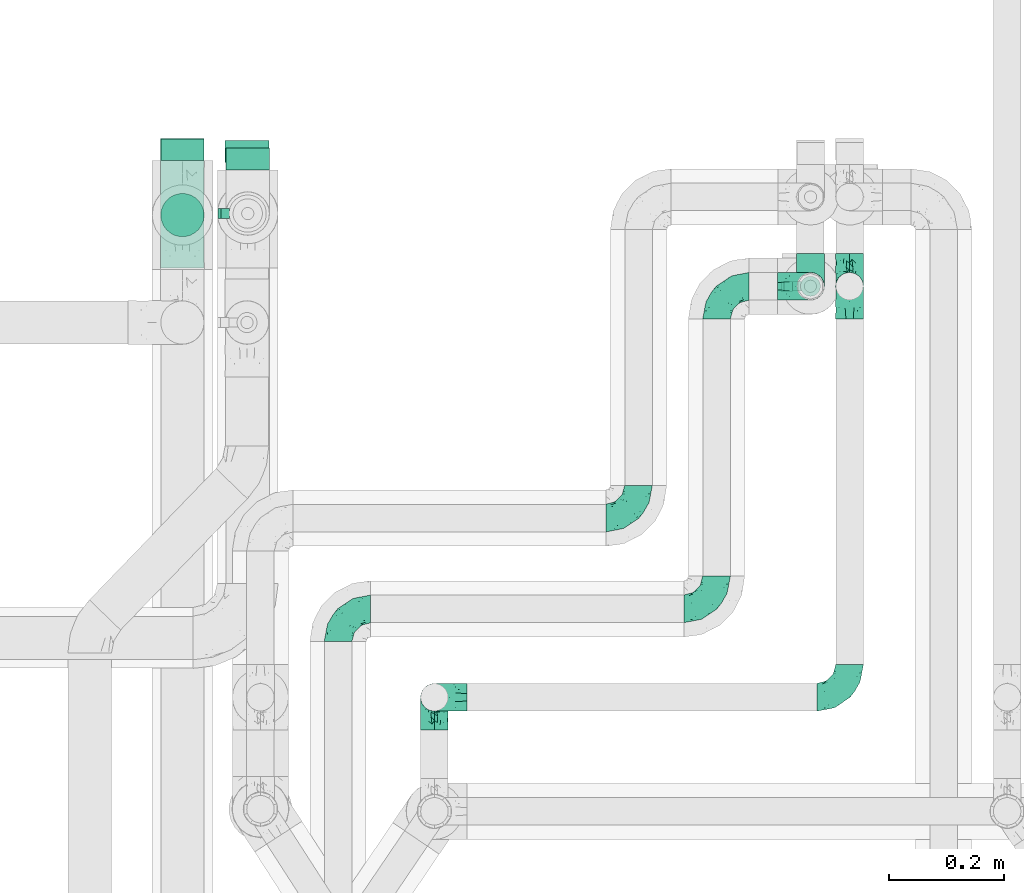
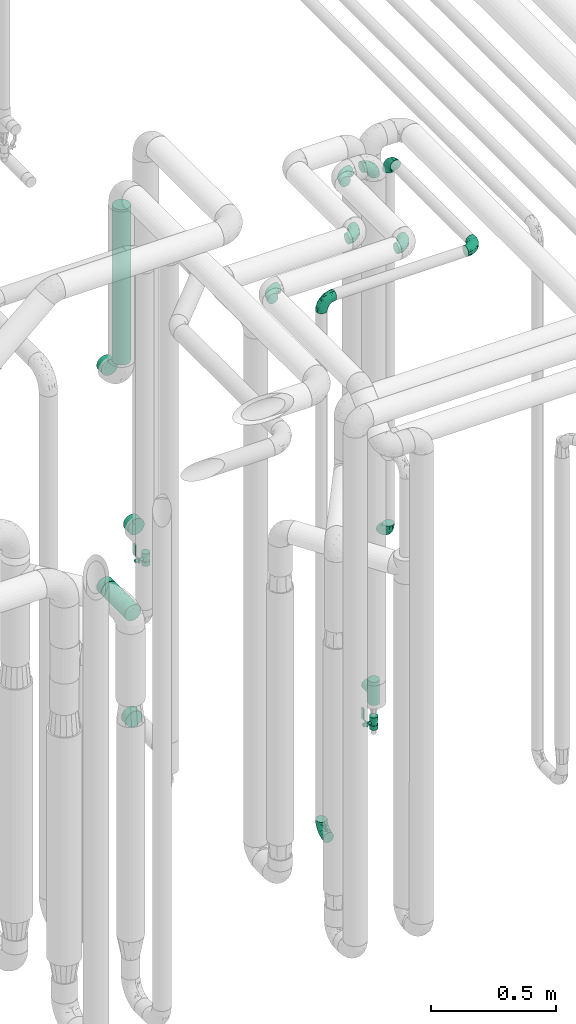
# One storey, part 672 of 824: 15 flow fittings, 2 flow controllers, 2 flow segments.
"""IFC2X3 building model written with IfcOpenShell, lengths in millimetres."""

from ifc_helpers import new_model, entity, si_unit, converted_unit, derived_unit, direction, frame, origin, origin_2d_with_axis, place, context, subcontext, project, spatial, polyline, circle, outline, extrude, faceted_brep, source, transform, mapped, material, material_list, type_object, type_shapes, element, save


model = new_model("IFC2X3")

# Units and contexts
model_context = context("Model", 3, precision=0.01, world=origin(), true_north=direction((6.12303176911189e-17, 1.0)))
body_context = subcontext(model_context, "Body", "Model", "MODEL_VIEW")
ifc_project = project(units=[si_unit("LENGTHUNIT", "METRE", prefix="MILLI"), si_unit("AREAUNIT", "SQUARE_METRE"), si_unit("VOLUMEUNIT", "CUBIC_METRE"), converted_unit("PLANEANGLEUNIT", "DEGREE", entity("IfcRatioMeasure", 0.0174532925199433), si_unit("PLANEANGLEUNIT", "RADIAN"), dimensions=[0, 0, 0, 0, 0, 0, 0]), si_unit("MASSUNIT", "GRAM", prefix="KILO"), derived_unit("MASSDENSITYUNIT", [(si_unit("MASSUNIT", "GRAM", prefix="KILO"), 1), (si_unit("LENGTHUNIT", "METRE"), -3)]), derived_unit("MOMENTOFINERTIAUNIT", [(si_unit("LENGTHUNIT", "METRE"), 4)]), si_unit("TIMEUNIT", "SECOND"), si_unit("FREQUENCYUNIT", "HERTZ"), si_unit("THERMODYNAMICTEMPERATUREUNIT", "DEGREE_CELSIUS"), derived_unit("THERMALTRANSMITTANCEUNIT", [(si_unit("MASSUNIT", "GRAM", prefix="KILO"), 1), (si_unit("THERMODYNAMICTEMPERATUREUNIT", "KELVIN"), -1), (si_unit("TIMEUNIT", "SECOND"), -3)]), derived_unit("VOLUMETRICFLOWRATEUNIT", [(si_unit("LENGTHUNIT", "METRE"), 3), (si_unit("TIMEUNIT", "SECOND"), -1)]), derived_unit("MASSFLOWRATEUNIT", [(si_unit("MASSUNIT", "GRAM", prefix="KILO"), 1), (si_unit("TIMEUNIT", "SECOND"), -1)]), derived_unit("ROTATIONALFREQUENCYUNIT", [(si_unit("TIMEUNIT", "SECOND"), -1)]), si_unit("ELECTRICCURRENTUNIT", "AMPERE"), si_unit("ELECTRICVOLTAGEUNIT", "VOLT"), si_unit("POWERUNIT", "WATT"), si_unit("FORCEUNIT", "NEWTON", prefix="KILO"), si_unit("ILLUMINANCEUNIT", "LUX"), si_unit("LUMINOUSFLUXUNIT", "LUMEN"), si_unit("LUMINOUSINTENSITYUNIT", "CANDELA"), derived_unit("USERDEFINED", [(si_unit("MASSUNIT", "GRAM", prefix="KILO"), -1), (si_unit("LENGTHUNIT", "METRE"), -2), (si_unit("TIMEUNIT", "SECOND"), 3), (si_unit("LUMINOUSFLUXUNIT", "LUMEN"), 1)]), derived_unit("LINEARVELOCITYUNIT", [(si_unit("LENGTHUNIT", "METRE"), 1), (si_unit("TIMEUNIT", "SECOND"), -1)]), si_unit("PRESSUREUNIT", "PASCAL"), derived_unit("USERDEFINED", [(si_unit("LENGTHUNIT", "METRE"), -2), (si_unit("MASSUNIT", "GRAM", prefix="KILO"), 1), (si_unit("TIMEUNIT", "SECOND"), -2)]), derived_unit("LINEARFORCEUNIT", [(si_unit("MASSUNIT", "GRAM", prefix="KILO"), 1), (si_unit("LENGTHUNIT", "METRE"), 1), (si_unit("TIMEUNIT", "SECOND"), -2), (si_unit("LENGTHUNIT", "METRE"), -1)]), derived_unit("PLANARFORCEUNIT", [(si_unit("MASSUNIT", "GRAM", prefix="KILO"), 1), (si_unit("LENGTHUNIT", "METRE"), 1), (si_unit("TIMEUNIT", "SECOND"), -2), (si_unit("LENGTHUNIT", "METRE"), -2)])], contexts=[model_context])

# Site, building, storey
site_placement = place(None, origin())
site = spatial("IfcSite", under=ifc_project, at=site_placement, CompositionType="ELEMENT")
building_placement = place(site_placement, origin())
building = spatial("IfcBuilding", under=site, at=building_placement, CompositionType="ELEMENT")
storey_placement = place(building_placement, frame((0.0, 0.0, 28200.0)))
storey = spatial("IfcBuildingStorey", under=building, at=storey_placement, CompositionType="ELEMENT", Elevation=28200.0)

# Flow segments
pipe_segment_type = type_object("IfcPipeSegmentType", PredefinedType="NOTDEFINED")
flow_segment_1_placement = place(storey_placement, frame((46517.3, 15183.04, 1125.65)))
element("IfcFlowSegment", 1, at=flow_segment_1_placement, inside=storey, type_object=pipe_segment_type, context=body_context, shape_type="SweptSolid", body=[
    extrude(circle(Radius=37.75, at=origin_2d_with_axis()), frame((39.35, 0.0, 39.35), z_axis=(0.0, 1.0, 0.0), x_axis=(1.0, 0.0, 0.0)), (0.0, 0.0, 1.0), 188.200000000003),
])
flow_segment_2_placement = place(storey_placement, frame((46517.43, 15236.02, 2345.05)))
element("IfcFlowSegment", 2, at=flow_segment_2_placement, inside=storey, type_object=pipe_segment_type, context=body_context, shape_type="SweptSolid", body=[
    extrude(circle(Radius=37.75, at=origin_2d_with_axis()), frame((39.35, 39.35, 0.0)), (0.0, 0.0, 1.0), 760.000000000018),
])

# Flow controllers
ifc_material = material()
ifc_material_list = material_list([ifc_material, ifc_material, ifc_material, ifc_material, ifc_material])
valve_type = type_object("IfcValveType", PredefinedType="NOTDEFINED", material=ifc_material_list)
shared_shape_1 = source(origin(), body_context, "Body", "SweptSolid", [
    extrude(circle(Radius=17.5, at=origin_2d_with_axis()), frame((-30.5, 0.0, 0.0), z_axis=(1.0, 0.0, 0.0), x_axis=(0.0, 1.0, 0.0)), (0.0, 0.0, 1.0), 20.3333333333333),
    extrude(circle(Radius=16.0, at=origin_2d_with_axis()), frame((-10.17, 0.0, 0.0), z_axis=(1.0, 0.0, 0.0), x_axis=(0.0, 1.0, 0.0)), (0.0, 0.0, 1.0), 20.3333333333333),
    extrude(circle(Radius=17.5, at=origin_2d_with_axis()), frame((10.17, 0.0, 0.0), z_axis=(1.0, 0.0, 0.0), x_axis=(0.0, 1.0, 0.0)), (0.0, 0.0, 1.0), 20.3333333333333),
    extrude(outline(polyline([(-38.75, -5.0), (-38.75, -10.0), (-17.92, -10.0), (2.08, 5.0), (56.25, 5.0), (56.25, 10.0), (0.42, 10.0), (-19.58, -5.0), (-38.75, -5.0)])), frame((28.75, -8.75, 41.5), z_axis=(0.0, -1.0, 0.0), x_axis=(1.0, 0.0, 0.0)), (0.0, 0.0, -1.0), 17.5),
    extrude(circle(Radius=8.0, at=origin_2d_with_axis()), origin(), (0.0, 0.0, 1.0), 49.0),
])
type_shapes(valve_type, [shared_shape_1])
for number, where, z_axis, x_axis in (
    (3, (47651.75, 15151.24, 267.75), (-1.0, 0.0, 0.0), (0.0, 0.0, 1.0)),
    (4, (46670.56, 15278.08, 1335.75), (-1.0, 0.0, 0.0), (0.0, 0.0, 1.0)),
):
    element("IfcFlowController", number, at=place(storey_placement, frame(where, z_axis=z_axis, x_axis=x_axis)), inside=storey, type_object=valve_type, material=ifc_material, context=body_context, shape_type="MappedRepresentation", body=[
        mapped(shared_shape_1, transform((0.0, 0.0, 0.0), scale=1.0)),
    ])

# Flow fittings
pipe_fitting_type_1 = type_object("IfcPipeFittingType", PredefinedType="NOTDEFINED", material=ifc_material)
shared_shape_2 = source(origin(), body_context, "Body", "SweptSolid", [
    extrude(circle(Radius=38.05, at=origin_2d_with_axis()), frame((0.0, 0.0, 0.0), z_axis=(1.0, 0.0, 0.0), x_axis=(0.0, 1.0, 0.0)), (0.0, 0.0, 1.0), 38.0000000000003),
])
type_shapes(pipe_fitting_type_1, [shared_shape_2])
for number, where, z_axis, x_axis in (
    (5, (46556.77, 15370.36, 2250.05), (1.0, 0.0, 0.0), (0.0, 1.0, 0.0)),
    (6, (46670.56, 15354.08, 1442.25), (-1.0, 0.0, 0.0), (0.0, 1.0, 0.0)),
    (7, (46556.64, 15371.24, 1165.0), (0.0, 0.0, 1.0), (0.0, 1.0, 0.0)),
    (8, (46669.38, 15367.24, 494.0), (0.0, 0.0, 1.0), (0.0, 1.0, 0.0)),
):
    element("IfcFlowFitting", number, at=place(storey_placement, frame(where, z_axis=z_axis, x_axis=x_axis)), inside=storey, type_object=pipe_fitting_type_1, material=ifc_material, context=body_context, shape_type="MappedRepresentation", body=[
        mapped(shared_shape_2, transform((0.0, 0.0, 0.0), scale=1.0)),
    ])
pipe_fitting_type_2 = type_object("IfcPipeFittingType", PredefinedType="NOTDEFINED", material=ifc_material)
shared_shape_3 = source(origin(), body_context, "Body", "Brep", [
    faceted_brep([(-57.0, 12.07, -20.91), (-57.0, 6.25, -23.33), (-57.0, 0.0, -24.15), (-57.0, -6.25, -23.33), (-57.0, -12.08, -20.91), (-57.0, -17.08, -17.08), (-57.0, -20.91, -12.08), (-57.0, -23.33, -6.25), (-57.0, -24.15, 0.0), (-57.0, -23.33, 6.25), (-57.0, -20.91, 12.07), (-57.0, -17.08, 17.08), (-57.0, -12.08, 20.91), (-57.0, -6.25, 23.33), (-57.0, 0.0, 24.15), (-57.0, 6.25, 23.33), (-57.0, 12.07, 20.91), (-57.0, 17.08, 17.08), (-57.0, 20.91, 12.07), (-57.0, 23.33, 6.25), (-57.0, 24.15, 0.0), (-57.0, 23.33, -6.25), (-57.0, 20.91, -12.08), (-57.0, 17.08, -17.08), (0.0, 57.0, -24.15), (-6.25, 57.0, -23.33), (-12.07, 57.0, -20.91), (-17.08, 57.0, -17.08), (-20.91, 57.0, -12.08), (-23.33, 57.0, -6.25), (-24.15, 57.0, 0.0), (-23.33, 57.0, 6.25), (-20.91, 57.0, 12.07), (-17.08, 57.0, 17.08), (-12.07, 57.0, 20.91), (-6.25, 57.0, 23.33), (0.0, 57.0, 24.15), (6.25, 57.0, 23.33), (12.08, 57.0, 20.91), (17.08, 57.0, 17.08), (20.91, 57.0, 12.07), (23.33, 57.0, 6.25), (24.15, 57.0, 0.0), (23.33, 57.0, -6.25), (20.91, 57.0, -12.08), (17.08, 57.0, -17.08), (12.08, 57.0, -20.91), (6.25, 57.0, -23.33), (14.9, 21.14, 6.17), (13.61, 24.64, 12.48), (6.23, 8.95, 8.98), (-41.47, -21.06, 0.0), (-41.92, -18.38, 13.72), (-24.64, -13.61, 12.48), (-37.37, -13.24, 18.15), (-6.8, -4.93, 8.18), (-21.76, -15.19, 6.22), (-12.78, -9.18, 0.0), (-37.73, -20.51, 7.75), (-7.38, 7.38, 20.24), (-23.37, -4.26, 20.42), (-11.9, -3.19, 15.86), (-42.14, -8.7, 21.82), (13.24, 37.37, 18.15), (9.33, 23.53, 16.85), (4.26, 23.37, 20.42), (2.77, 10.92, 15.55), (-29.46, 0.91, 23.52), (-44.13, 20.56, 15.69), (-39.25, 26.33, 10.88), (-49.02, 22.92, 9.96), (-34.58, 23.87, 17.15), (-15.8, 6.8, 22.81), (-8.67, 20.47, 23.88), (-18.12, 12.9, 24.08), (-48.29, 14.92, 19.65), (-44.06, -2.85, 23.78), (-9.23, 48.95, 22.58), (-3.78, 42.74, 24.07), (-40.34, 4.26, 24.09), (-44.02, 26.14, 5.46), (-44.04, 9.88, 22.74), (-4.95, 16.87, 22.52), (-2.75, 1.43, 12.5), (-25.48, 40.98, 10.71), (20.51, 37.73, 7.75), (18.38, 41.92, 13.72), (8.7, 42.14, 21.82), (-25.95, -17.97, 0.0), (2.85, 44.06, 23.78), (21.06, 41.47, 0.0), (17.97, 25.95, 0.0), (-24.04, -9.27, 17.13), (-33.26, 33.26, 5.86), (-28.55, 40.57, 0.0), (-40.57, 28.55, 0.0), (-25.29, 47.19, 4.06), (-27.01, 31.1, 16.77), (-15.7, 43.95, 19.9), (-20.27, 45.22, 15.61), (-30.53, 31.98, 12.64), (-11.28, 38.33, 22.92), (-9.97, 27.88, 24.09), (-20.15, 30.26, 21.25), (-31.25, 11.75, 23.64), (-28.75, 7.23, 24.15), (-29.53, 18.06, 22.27), (-28.44, 24.21, 20.02), (-37.55, 17.7, 20.26), (-15.88, 29.25, 22.99), (-20.82, 20.82, 23.44), (-0.91, 29.46, 23.52), (-13.5, -7.67, 12.04), (1.49, 1.56, 5.16), (8.86, 10.35, 4.59), (0.38, -0.38, 0.0), (9.18, 12.78, 0.0), (-37.37, -13.24, -18.15), (8.86, 10.35, -4.59), (-45.22, 20.27, -15.61), (-43.95, 15.7, -19.9), (-38.33, 11.28, -22.92), (-48.95, 9.23, -22.58), (-47.19, 25.29, -4.06), (-33.26, 33.26, -5.86), (18.38, 41.92, -13.72), (-30.26, 20.15, -21.25), (2.85, 44.06, -23.78), (-4.26, 40.34, -24.09), (-40.98, 25.48, -10.71), (-41.92, -18.38, -13.72), (9.25, 23.5, -16.92), (4.26, 23.37, -20.42), (13.24, 37.37, -18.15), (-37.73, -20.51, -7.75), (-11.75, 31.25, -23.64), (-7.23, 28.75, -24.15), (-12.9, 18.12, -24.08), (8.7, 42.14, -21.82), (-44.06, -2.85, -23.78), (-6.8, 15.8, -22.81), (-20.47, 8.67, -23.88), (-24.64, -13.61, -12.48), (-42.74, 3.78, -24.07), (-18.06, 29.53, -22.27), (-24.21, 28.44, -20.02), (-27.88, 9.97, -24.09), (-31.1, 27.01, -16.77), (-26.14, 44.02, -5.46), (14.9, 21.14, -6.17), (20.51, 37.73, -7.75), (-9.88, 44.04, -22.74), (-20.56, 44.13, -15.69), (-21.76, -15.19, -6.22), (-13.5, -7.67, -12.04), (-24.14, -9.76, -16.74), (-11.9, -3.19, -15.86), (-14.92, 48.29, -19.65), (-23.37, -4.26, -20.42), (-0.91, 29.46, -23.52), (-26.33, 39.25, -10.88), (-23.87, 34.58, -17.15), (-42.14, -8.7, -21.82), (-22.92, 49.02, -9.96), (13.61, 24.64, -12.48), (-31.98, 30.53, -12.64), (-16.87, 4.95, -22.52), (-17.7, 37.55, -20.26), (-29.25, 15.88, -22.99), (-20.82, 20.82, -23.44), (-29.46, 0.91, -23.52), (-7.38, 7.38, -20.24), (2.77, 10.92, -15.55), (6.23, 8.95, -8.98), (-6.8, -4.93, -8.18), (-2.81, 1.41, -12.54), (1.49, 1.56, -5.16)], [[[0, 1, 2, 3, 4, 5, 6, 7, 8, 9, 10, 11, 12, 13, 14, 15, 16, 17, 18, 19, 20, 21, 22, 23]], [[24, 25, 26, 27, 28, 29, 30, 31, 32, 33, 34, 35, 36, 37, 38, 39, 40, 41, 42, 43, 44, 45, 46, 47]], [[48, 49, 50]], [[9, 8, 51]], [[52, 53, 54]], [[55, 56, 57]], [[10, 58, 52]], [[9, 58, 10]], [[59, 60, 61]], [[54, 12, 11]], [[54, 62, 12]], [[63, 39, 38]], [[64, 65, 66]], [[62, 60, 67]], [[68, 69, 70]], [[71, 69, 68]], [[72, 73, 74]], [[16, 75, 17]], [[13, 76, 14]], [[35, 77, 78]], [[14, 79, 15]], [[17, 68, 18]], [[14, 76, 79]], [[20, 19, 80]], [[70, 19, 18]], [[81, 15, 79]], [[15, 81, 16]], [[73, 72, 82]], [[66, 83, 50]], [[32, 31, 84]], [[85, 86, 49]], [[63, 87, 65]], [[56, 58, 88]], [[36, 89, 37]], [[85, 41, 40]], [[36, 35, 78]], [[90, 41, 85]], [[40, 39, 86]], [[12, 62, 13]], [[86, 85, 40]], [[48, 85, 49]], [[85, 91, 90]], [[87, 38, 37]], [[92, 60, 54]], [[80, 69, 93]], [[93, 94, 95]], [[10, 52, 11]], [[94, 96, 30]], [[97, 98, 99]], [[80, 93, 95]], [[100, 97, 84]], [[99, 98, 33]], [[101, 102, 78]], [[103, 101, 98]], [[96, 31, 30]], [[77, 98, 101]], [[77, 35, 34]], [[34, 33, 98]], [[9, 51, 58]], [[87, 63, 38]], [[104, 105, 74]], [[106, 103, 107]], [[106, 81, 104]], [[75, 68, 17]], [[108, 107, 71]], [[33, 32, 99]], [[109, 103, 110]], [[101, 109, 102]], [[89, 78, 111]], [[53, 52, 58]], [[54, 11, 52]], [[60, 62, 54]], [[88, 58, 51]], [[76, 62, 67]], [[53, 112, 92]], [[60, 59, 72]], [[39, 63, 86]], [[49, 86, 63]], [[89, 87, 37]], [[42, 41, 90]], [[111, 82, 65]], [[111, 65, 87]], [[65, 59, 66]], [[104, 81, 79]], [[75, 81, 108]], [[32, 84, 99]], [[97, 99, 84]], [[98, 97, 103]], [[106, 107, 108]], [[74, 102, 110]], [[111, 78, 102]], [[74, 110, 104]], [[74, 67, 72]], [[61, 92, 112]], [[66, 59, 61]], [[56, 53, 58]], [[66, 50, 49]], [[61, 112, 83]], [[66, 49, 64]], [[78, 89, 36]], [[87, 89, 111]], [[62, 76, 13]], [[79, 76, 67]], [[100, 93, 69]], [[96, 93, 84]], [[55, 113, 50]], [[113, 114, 50]], [[104, 79, 105]], [[106, 104, 110]], [[20, 80, 95]], [[85, 48, 91]], [[115, 114, 113]], [[116, 91, 48]], [[70, 80, 19]], [[93, 96, 94]], [[84, 31, 96]], [[103, 106, 110]], [[81, 106, 108]], [[103, 97, 107]], [[71, 107, 97]], [[71, 97, 100]], [[108, 71, 68]], [[79, 67, 105]], [[67, 74, 105]], [[115, 113, 57]], [[112, 56, 55]], [[56, 88, 57]], [[60, 72, 67]], [[82, 72, 59]], [[65, 82, 59]], [[82, 111, 73]], [[111, 102, 73]], [[102, 74, 73]], [[81, 75, 16]], [[68, 75, 108]], [[68, 70, 18]], [[80, 70, 69]], [[98, 77, 34]], [[78, 77, 101]], [[93, 100, 84]], [[71, 100, 69]], [[102, 109, 110]], [[101, 103, 109]], [[53, 92, 54]], [[61, 60, 92]], [[56, 112, 53]], [[83, 112, 55]], [[50, 83, 55]], [[61, 83, 66]], [[49, 63, 64]], [[65, 64, 63]], [[57, 113, 55]], [[114, 115, 116]], [[116, 48, 114]], [[48, 50, 114]], [[117, 5, 4]], [[116, 115, 118]], [[119, 120, 23]], [[121, 122, 120]], [[95, 123, 20]], [[0, 23, 120]], [[124, 95, 94]], [[125, 45, 44]], [[121, 120, 126]], [[24, 127, 128]], [[22, 21, 129]], [[0, 122, 1]], [[5, 117, 130]], [[131, 132, 133]], [[134, 88, 51]], [[135, 136, 137]], [[6, 5, 130]], [[46, 138, 47]], [[139, 3, 2]], [[140, 141, 137]], [[6, 134, 7]], [[134, 130, 142]], [[143, 2, 1]], [[144, 126, 145]], [[121, 146, 143]], [[147, 120, 119]], [[94, 148, 124]], [[149, 150, 91]], [[30, 29, 148]], [[151, 25, 128]], [[27, 152, 28]], [[134, 153, 88]], [[154, 155, 156]], [[27, 26, 157]], [[151, 26, 25]], [[155, 158, 156]], [[24, 47, 127]], [[1, 122, 143]], [[138, 132, 159]], [[160, 152, 161]], [[24, 128, 25]], [[46, 133, 138]], [[162, 117, 4]], [[148, 160, 124]], [[152, 160, 163]], [[154, 142, 155]], [[45, 125, 133]], [[133, 46, 45]], [[125, 164, 133]], [[51, 7, 134]], [[42, 90, 43]], [[165, 147, 129]], [[153, 134, 142]], [[43, 150, 44]], [[162, 4, 3]], [[141, 140, 166]], [[117, 162, 158]], [[163, 29, 28]], [[43, 90, 150]], [[123, 21, 20]], [[144, 151, 135]], [[157, 152, 27]], [[167, 145, 161]], [[23, 22, 119]], [[168, 126, 169]], [[121, 168, 146]], [[139, 143, 170]], [[142, 130, 117]], [[8, 7, 51]], [[134, 6, 130]], [[139, 162, 3]], [[170, 166, 158]], [[170, 158, 162]], [[158, 171, 156]], [[44, 150, 125]], [[91, 150, 90]], [[164, 125, 150]], [[132, 138, 133]], [[127, 138, 159]], [[131, 164, 172]], [[132, 171, 140]], [[135, 151, 128]], [[157, 151, 167]], [[22, 129, 119]], [[147, 119, 129]], [[120, 147, 126]], [[144, 145, 167]], [[137, 146, 169]], [[170, 143, 146]], [[137, 169, 135]], [[137, 159, 140]], [[171, 172, 156]], [[173, 174, 175]], [[156, 175, 154]], [[174, 57, 153]], [[132, 172, 171]], [[172, 164, 173]], [[143, 139, 2]], [[162, 139, 170]], [[138, 127, 47]], [[128, 127, 159]], [[165, 124, 160]], [[123, 124, 129]], [[149, 173, 164]], [[176, 174, 173]], [[135, 128, 136]], [[144, 135, 169]], [[150, 149, 164]], [[176, 118, 115]], [[149, 91, 116]], [[30, 148, 94]], [[163, 148, 29]], [[124, 123, 95]], [[129, 21, 123]], [[126, 144, 169]], [[151, 144, 167]], [[126, 147, 145]], [[161, 145, 147]], [[161, 147, 165]], [[167, 161, 152]], [[128, 159, 136]], [[159, 137, 136]], [[154, 153, 142]], [[132, 140, 159]], [[174, 176, 57]], [[57, 88, 153]], [[166, 140, 171]], [[158, 166, 171]], [[166, 170, 141]], [[170, 146, 141]], [[146, 137, 141]], [[151, 157, 26]], [[152, 157, 167]], [[152, 163, 28]], [[148, 163, 160]], [[120, 122, 0]], [[143, 122, 121]], [[124, 165, 129]], [[161, 165, 160]], [[146, 168, 169]], [[121, 126, 168]], [[142, 117, 155]], [[158, 155, 117]], [[175, 156, 172]], [[153, 154, 174]], [[173, 175, 172]], [[174, 154, 175]], [[164, 131, 133]], [[172, 132, 131]], [[176, 173, 118]], [[57, 176, 115]], [[173, 149, 118]], [[149, 116, 118]]]),
])
type_shapes(pipe_fitting_type_2, [shared_shape_3])
for number, where, z_axis, x_axis in (
    (9, (46996.03, 14434.53, 400.0), (-1.0, 0.0, 0.0), (0.0, 0.0, -1.0)),
    (10, (47720.02, 15151.24, 3000.0), (-1.0, 0.0, 0.0), (0.0, 1.0, 0.0)),
    (11, (47720.02, 15151.24, 1160.0), (1.0, 0.0, 0.0), (0.0, 0.0, -1.0)),
    (12, (47488.0, 15151.24, 3000.0), (0.0, 0.0, 1.0), (-1.0, 0.0, 0.0)),
    (13, (47651.75, 15151.24, 3000.0), (0.0, 1.0, 0.0), (1.0, 0.0, 0.0)),
):
    element("IfcFlowFitting", number, at=place(storey_placement, frame(where, z_axis=z_axis, x_axis=x_axis)), inside=storey, type_object=pipe_fitting_type_2, material=ifc_material, context=body_context, shape_type="MappedRepresentation", body=[
        mapped(shared_shape_3, transform((0.0, 0.0, 0.0), scale=1.0)),
    ])
flow_fitting_1_placement = place(storey_placement, frame((47720.02, 14434.53, 3000.0)))
element("IfcFlowFitting", 14, at=flow_fitting_1_placement, inside=storey, type_object=pipe_fitting_type_2, material=ifc_material, context=body_context, shape_type="MappedRepresentation", body=[
    mapped(shared_shape_3, transform((0.0, 0.0, 0.0), scale=1.0)),
])
flow_fitting_2_placement = place(storey_placement, frame((46996.03, 14434.53, 3000.0), z_axis=(0.0, 1.0, 0.0), x_axis=(0.0, 0.0, 1.0)))
element("IfcFlowFitting", 15, at=flow_fitting_2_placement, inside=storey, type_object=pipe_fitting_type_2, material=ifc_material, context=body_context, shape_type="MappedRepresentation", body=[
    mapped(shared_shape_3, transform((0.0, 0.0, 0.0), scale=1.0)),
])
flow_fitting_3_placement = place(storey_placement, frame((47488.0, 14588.75, 3000.0)))
element("IfcFlowFitting", 16, at=flow_fitting_3_placement, inside=storey, type_object=pipe_fitting_type_2, material=ifc_material, context=body_context, shape_type="MappedRepresentation", body=[
    mapped(shared_shape_3, transform((0.0, 0.0, 0.0), scale=1.0)),
])
flow_fitting_4_placement = place(storey_placement, frame((46828.0, 14588.75, 3000.0), z_axis=(0.0, 0.0, 1.0), x_axis=(-1.0, 0.0, 0.0)))
element("IfcFlowFitting", 17, at=flow_fitting_4_placement, inside=storey, type_object=pipe_fitting_type_2, material=ifc_material, context=body_context, shape_type="MappedRepresentation", body=[
    mapped(shared_shape_3, transform((0.0, 0.0, 0.0), scale=1.0)),
])
flow_fitting_5_placement = place(storey_placement, frame((47352.0, 14747.03, 3000.0)))
element("IfcFlowFitting", 18, at=flow_fitting_5_placement, inside=storey, type_object=pipe_fitting_type_2, material=ifc_material, context=body_context, shape_type="MappedRepresentation", body=[
    mapped(shared_shape_3, transform((0.0, 0.0, 0.0), scale=1.0)),
])
pipe_fitting_type_3 = type_object("IfcPipeFittingType", PredefinedType="NOTDEFINED", material=ifc_material)
shared_shape_4 = source(origin(), body_context, "Body", "Brep", [
    faceted_brep([(-57.0, 12.07, -20.91), (-57.0, 6.25, -23.33), (-57.0, 0.0, -24.15), (-57.0, -6.25, -23.33), (-57.0, -12.08, -20.91), (-57.0, -17.08, -17.08), (-57.0, -20.91, -12.08), (-57.0, -23.33, -6.25), (-57.0, -24.15, 0.0), (-57.0, -23.33, 6.25), (-57.0, -20.91, 12.07), (-57.0, -17.08, 17.08), (-57.0, -12.08, 20.91), (-57.0, -6.25, 23.33), (-57.0, 0.0, 24.15), (-57.0, 6.25, 23.33), (-57.0, 12.07, 20.91), (-57.0, 17.08, 17.08), (-57.0, 20.91, 12.07), (-57.0, 23.33, 6.25), (-57.0, 24.15, 0.0), (-57.0, 23.33, -6.25), (-57.0, 20.91, -12.08), (-57.0, 17.08, -17.08), (57.0, 0.0, -24.15), (57.0, 6.25, -23.33), (57.0, 12.07, -20.91), (57.0, 17.08, -17.08), (57.0, 20.91, -12.08), (57.0, 23.33, -6.25), (57.0, 24.15, 0.0), (57.0, 23.33, 6.25), (57.0, 20.91, 12.07), (57.0, 17.08, 17.08), (57.0, 12.07, 20.91), (57.0, 6.25, 23.33), (57.0, 0.0, 24.15), (57.0, -6.25, 23.33), (57.0, -12.08, 20.91), (57.0, -17.08, 17.08), (57.0, -20.91, 12.07), (57.0, -23.33, 6.25), (57.0, -24.15, 0.0), (57.0, -23.33, -6.25), (57.0, -20.91, -12.08), (57.0, -17.08, -17.08), (57.0, -12.08, -20.91), (57.0, -6.25, -23.33), (23.27, -23.27, 6.45), (24.15, -24.15, 0.0), (-24.15, -24.15, 0.0), (20.9, -20.9, 12.1), (13.54, -13.54, 20.0), (17.52, -17.52, 16.62), (-23.27, -23.27, 6.45), (-20.9, -20.9, 12.1), (-17.52, -17.52, 16.62), (-13.54, -13.54, 20.0), (-9.19, -9.19, 22.33), (9.19, -9.19, 22.33), (4.64, -4.64, 23.7), (0.0, 0.0, 24.15), (-4.64, -4.64, 23.7), (4.64, -4.64, -23.7), (0.0, 0.0, -24.15), (-4.64, -4.64, -23.7), (-9.19, -9.19, -22.33), (9.19, -9.19, -22.33), (13.54, -13.54, -20.0), (17.52, -17.52, -16.62), (20.9, -20.9, -12.1), (23.27, -23.27, -6.45), (-13.54, -13.54, -20.0), (-17.52, -17.52, -16.62), (-23.27, -23.27, -6.45), (-20.9, -20.9, -12.1), (0.0, -57.0, -24.15), (6.25, -57.0, -23.33), (12.08, -57.0, -20.91), (17.08, -57.0, -17.08), (20.91, -57.0, -12.08), (23.33, -57.0, -6.25), (24.15, -57.0, 0.0), (23.33, -57.0, 6.25), (20.91, -57.0, 12.07), (17.08, -57.0, 17.08), (12.08, -57.0, 20.91), (6.25, -57.0, 23.33), (0.0, -57.0, 24.15), (-6.25, -57.0, 23.33), (-12.07, -57.0, 20.91), (-17.08, -57.0, 17.08), (-20.91, -57.0, 12.07), (-23.33, -57.0, 6.25), (-24.15, -57.0, 0.0), (-23.33, -57.0, -6.25), (-20.91, -57.0, -12.08), (-17.08, -57.0, -17.08), (-12.07, -57.0, -20.91), (-6.25, -57.0, -23.33)], [[[0, 1, 2, 3, 4, 5, 6, 7, 8, 9, 10, 11, 12, 13, 14, 15, 16, 17, 18, 19, 20, 21, 22, 23]], [[24, 25, 26, 27, 28, 29, 30, 31, 32, 33, 34, 35, 36, 37, 38, 39, 40, 41, 42, 43, 44, 45, 46, 47]], [[41, 40, 48]], [[42, 41, 49]], [[50, 9, 8]], [[49, 41, 48]], [[40, 51, 48]], [[39, 38, 52]], [[51, 40, 53]], [[52, 53, 39]], [[53, 40, 39]], [[50, 54, 9]], [[9, 54, 10]], [[54, 55, 10]], [[56, 57, 11]], [[11, 10, 56]], [[11, 57, 12]], [[56, 10, 55]], [[12, 57, 58]], [[52, 38, 59]], [[60, 36, 61]], [[62, 61, 14]], [[59, 37, 60]], [[37, 59, 38]], [[60, 37, 36]], [[61, 36, 35, 15, 14]], [[32, 31, 19, 18]], [[17, 16, 34, 33]], [[18, 17, 33, 32]], [[35, 34, 16, 15]], [[20, 19, 31, 30]], [[62, 13, 58]], [[13, 62, 14]], [[58, 13, 12]], [[27, 23, 22, 28]], [[22, 21, 29, 28]], [[0, 23, 27, 26]], [[20, 30, 29, 21]], [[24, 47, 63]], [[24, 64, 2, 1, 25]], [[64, 24, 63]], [[2, 64, 65]], [[26, 25, 1, 0]], [[65, 66, 3]], [[2, 65, 3]], [[66, 4, 3]], [[63, 47, 67]], [[46, 45, 68]], [[69, 68, 45]], [[44, 70, 69]], [[69, 45, 44]], [[46, 68, 67]], [[43, 42, 49]], [[7, 50, 8]], [[43, 71, 44]], [[71, 43, 49]], [[44, 71, 70]], [[72, 4, 66]], [[72, 5, 4]], [[5, 72, 73]], [[5, 73, 6]], [[74, 50, 7]], [[75, 74, 6]], [[74, 7, 6]], [[75, 6, 73]], [[46, 67, 47]], [[76, 77, 78, 79, 80, 81, 82, 83, 84, 85, 86, 87, 88, 89, 90, 91, 92, 93, 94, 95, 96, 97, 98, 99]], [[50, 94, 93]], [[54, 50, 93]], [[91, 90, 57]], [[56, 92, 91]], [[54, 93, 92]], [[58, 90, 89]], [[55, 54, 92]], [[56, 55, 92]], [[58, 57, 90]], [[88, 61, 62]], [[58, 89, 62]], [[56, 91, 57]], [[62, 89, 88]], [[60, 88, 87]], [[86, 59, 87]], [[84, 83, 48]], [[53, 85, 84]], [[52, 86, 85]], [[49, 83, 82]], [[59, 60, 87]], [[52, 59, 86]], [[49, 48, 83]], [[51, 53, 84]], [[48, 51, 84]], [[52, 85, 53]], [[88, 60, 61]], [[82, 81, 49]], [[71, 49, 81]], [[69, 80, 79]], [[79, 78, 68]], [[71, 81, 80]], [[67, 78, 77]], [[70, 71, 80]], [[69, 70, 80]], [[67, 68, 78]], [[76, 64, 63]], [[67, 77, 63]], [[69, 79, 68]], [[63, 77, 76]], [[65, 76, 99]], [[98, 66, 99]], [[96, 95, 74]], [[73, 97, 96]], [[72, 98, 97]], [[50, 95, 94]], [[66, 65, 99]], [[72, 66, 98]], [[50, 74, 95]], [[75, 73, 96]], [[74, 75, 96]], [[72, 97, 73]], [[76, 65, 64]]]),
])
type_shapes(pipe_fitting_type_3, [shared_shape_4])
flow_fitting_6_placement = place(storey_placement, frame((47651.75, 15151.24, 420.25), z_axis=(-1.0, 0.0, 0.0), x_axis=(0.0, 0.0, -1.0)))
element("IfcFlowFitting", 19, at=flow_fitting_6_placement, inside=storey, type_object=pipe_fitting_type_3, material=ifc_material, context=body_context, shape_type="MappedRepresentation", body=[
    mapped(shared_shape_4, transform((0.0, 0.0, 0.0), scale=1.0)),
])

save(model, "model.ifc")
